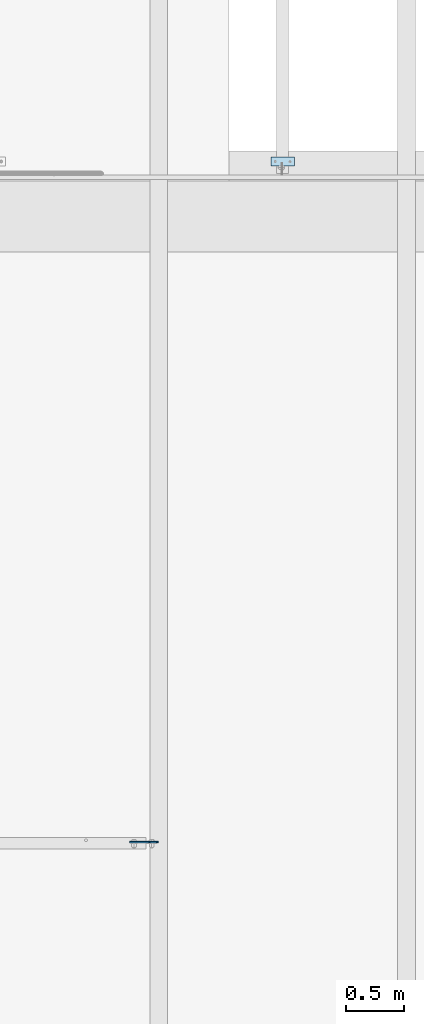
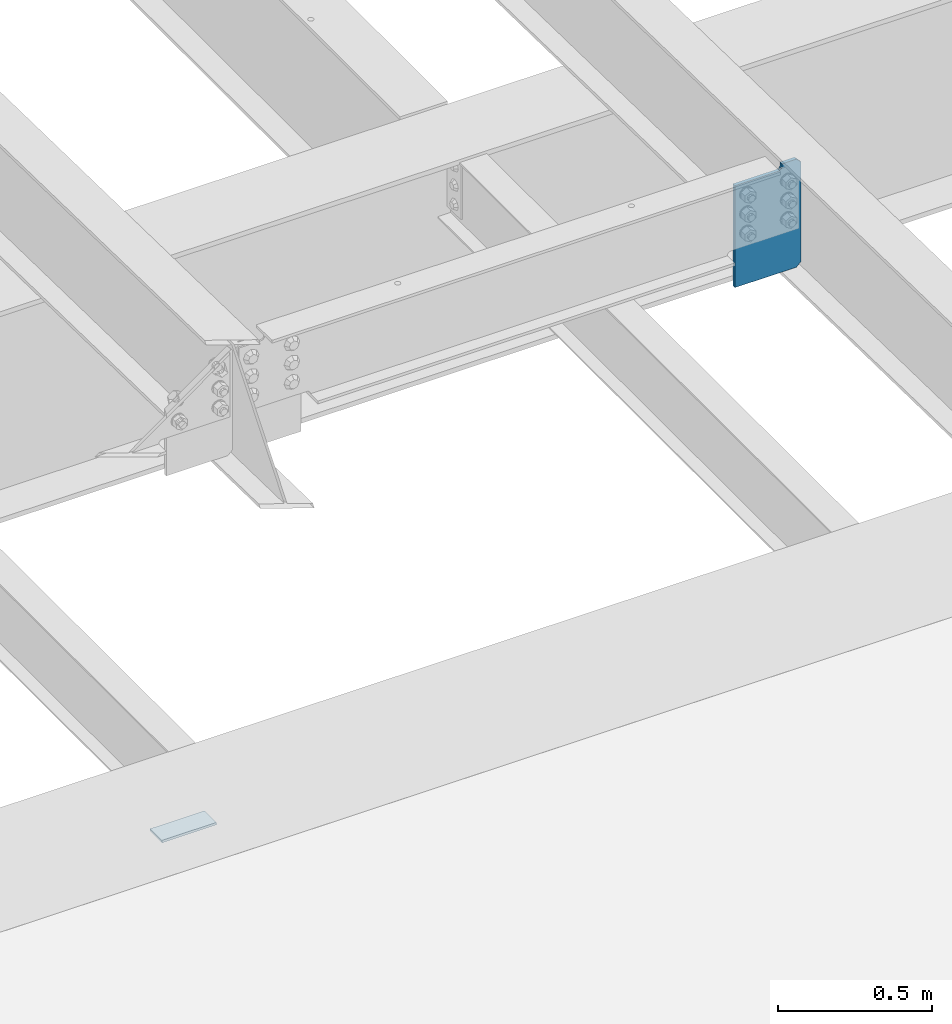
# One storey, part 1502 of 1763: 2 plates, 2 elements without a shape of their own.
"""IFC2X3 building model written with IfcOpenShell, lengths in millimetres."""

from ifc_helpers import new_model, si_unit, frame, origin_with_axes, place, context, subcontext, project, spatial, faceted_brep, material, type_object, element, aggregate, save


model = new_model("IFC2X3")

# Units and contexts
model_context = context("Model", 3, precision=1e-05, world=origin_with_axes())
body_context = subcontext(model_context, "Body", "Model", "MODEL_VIEW")
ifc_project = project(units=[si_unit("LENGTHUNIT", "METRE", prefix="MILLI"), si_unit("AREAUNIT", "SQUARE_METRE"), si_unit("VOLUMEUNIT", "CUBIC_METRE"), si_unit("MASSUNIT", "GRAM", prefix="KILO"), si_unit("TIMEUNIT", "SECOND"), si_unit("PLANEANGLEUNIT", "RADIAN"), si_unit("SOLIDANGLEUNIT", "STERADIAN"), si_unit("THERMODYNAMICTEMPERATUREUNIT", "DEGREE_CELSIUS"), si_unit("LUMINOUSINTENSITYUNIT", "LUMEN")], contexts=[model_context])

# Site, building, storey
site_placement = place(None, origin_with_axes())
site = spatial("IfcSite", under=ifc_project, at=site_placement, CompositionType="ELEMENT")
building_placement = place(site_placement, origin_with_axes())
building = spatial("IfcBuilding", under=site, at=building_placement, Name="Undefined", CompositionType="ELEMENT")
storey_placement = place(building_placement, origin_with_axes())
storey = spatial("IfcBuildingStorey", under=building, at=storey_placement, Name="Undefined", CompositionType="ELEMENT", Elevation=0.0)

# Assembly, plate
assembly_1_placement = place(storey_placement, origin_with_axes())
assembly_1 = element("IfcElementAssembly", 1, at=assembly_1_placement, inside=storey, Name="EMBED PLATE", AssemblyPlace="NOTDEFINED", PredefinedType="RIGID_FRAME")
ifc_material_1 = material(Name="STEEL/A36")
plate_type_1 = type_object("IfcPlateType", PredefinedType="NOTDEFINED")
plate_1_placement = place(assembly_1_placement, frame((-80034.8372736983, 27406.5999969482, 4884.7375), z_axis=(0.0, 1.0, 0.0), x_axis=(1.0, 0.0, 0.0)))
plate_1 = element("IfcPlate", 2, at=plate_1_placement, type_object=plate_type_1, material=ifc_material_1, Name="EMBED PLATE", context=body_context, shape_type="Brep", body=[
    faceted_brep([(0.0, -4.76249999999982, 0.0), (0.0, -4.76250000000073, 76.1999969482422), (0.0, 4.76250000000073, 76.1999969482422), (0.0, 4.76249999999982, 0.0), (203.199981689453, -4.76249999999982, 76.1999969482422), (203.199981689453, 4.76249999999982, 76.1999969482422), (203.199981689453, -4.76249999999982, 0.0), (203.199981689453, 4.76249999999982, 0.0)], [[[0, 1, 2, 3]], [[1, 4, 5, 2]], [[4, 6, 7, 5]], [[6, 0, 3, 7]], [[5, 7, 3, 2]], [[6, 4, 1, 0]]]),
])
aggregate(assembly_1, [plate_1])

assembly_2_placement = place(storey_placement, origin_with_axes())
assembly_2 = element("IfcElementAssembly", 3, at=assembly_2_placement, inside=storey, Name="BEAM", AssemblyPlace="NOTDEFINED", PredefinedType="RIGID_FRAME")
ifc_material_2 = material(Name="STEEL/A572-50")
plate_type_2 = type_object("IfcPlateType", PredefinedType="NOTDEFINED")
plate_2_placement = place(assembly_2_placement, frame((-81000.6774522698, 21599.5249999976, 11025.4076650543), z_axis=(0.0, 0.0, 1.0), x_axis=(-1.0, 0.0, 0.0)))
plate_2 = element("IfcPlate", 4, at=plate_2_placement, type_object=plate_type_2, material=ifc_material_2, Name="PLATE", context=body_context, shape_type="Brep", body=[
    faceted_brep([(71.9312438964844, -6.34999999999854, 427.853149414062), (71.9312438964844, -6.34999999999854, 415.787802696228), (71.9312438964844, 6.34999999999854, 415.787802696228), (71.9312438964844, 6.34999999999854, 427.853149414062), (72.8979738190683, -6.34999999999854, 410.927723178182), (72.8979738190683, 6.34999999999854, 410.927723178182), (75.6509877195494, -6.34999999999854, 406.807546710028), (75.6509877195494, 6.34999999999854, 406.807546710028), (79.7711641877104, -6.34999999999854, 404.05453280955), (79.7711641877104, 6.34999999999854, 404.05453280955), (84.6312437057495, -6.34999999999854, 403.087802886963), (84.6312437057495, 6.34999999999854, 403.087802886963), (247.649993896484, -6.34999999999854, 403.087802886963), (247.649993896484, 6.34999999999854, 403.087802886963), (0.0, -6.34999999999854, 410.390649795532), (17.4624996185303, -6.34999999999854, 427.853149414062), (17.4624996185303, 6.34999999999854, 427.853149414062), (0.0, 6.34999999999854, 410.390649795532), (0.0, -6.34999999999854, 17.4624996185303), (0.0, 6.34999999999854, 17.4624996185303), (17.4624996185303, -6.34999999999854, 0.0), (17.4624996185303, 6.34999999999854, 0.0), (247.649993896484, -6.34999999999854, 0.0), (247.649993896484, 6.34999999999854, 0.0)], [[[0, 1, 2, 3]], [[4, 5, 2, 1]], [[6, 7, 5, 4]], [[8, 9, 7, 6]], [[10, 11, 9, 8]], [[12, 13, 11, 10]], [[14, 15, 16, 17]], [[18, 14, 17, 19]], [[20, 18, 19, 21]], [[22, 20, 21, 23]], [[8, 6, 4, 1, 0, 15, 14, 18, 20, 22, 12, 10]], [[16, 15, 0, 3]], [[23, 21, 19, 17, 16, 3, 2, 5, 7, 9, 11, 13]], [[22, 23, 13, 12]]]),
])
aggregate(assembly_2, [plate_2])

save(model, "model.ifc")
